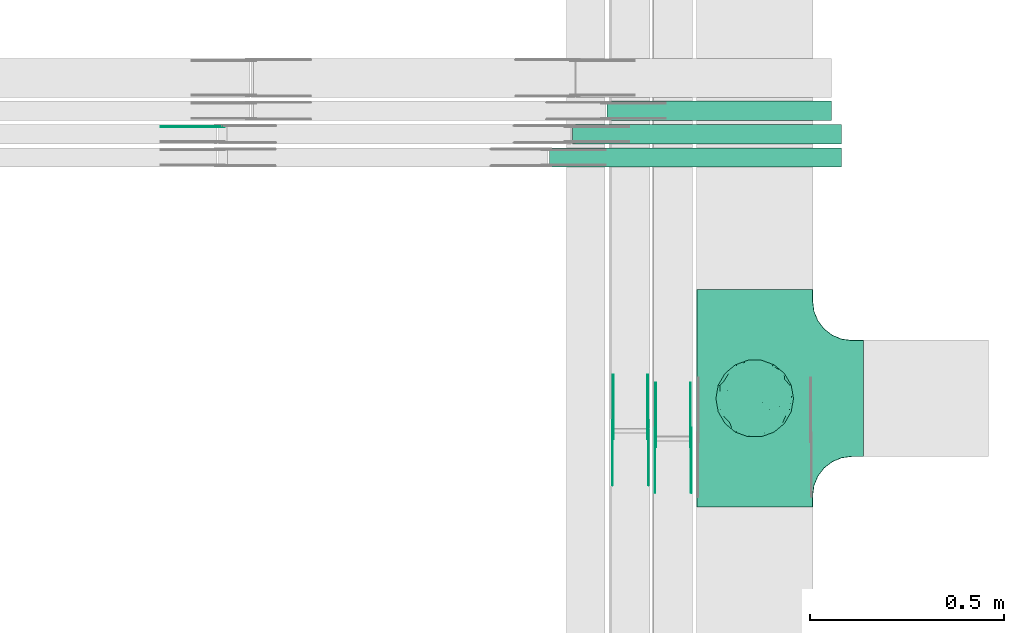
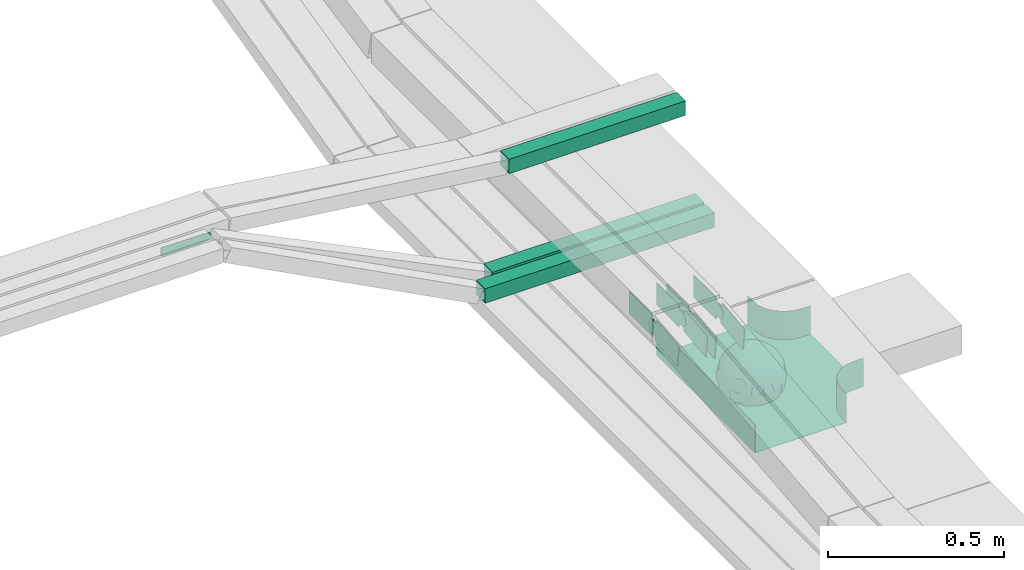
# One storey, part 6 of 32: 10 flow fittings, 3 flow segments.
"""IFC2X3 building model written with IfcOpenShell, lengths in millimetres."""

from ifc_helpers import new_model, entity, si_unit, converted_unit, derived_unit, direction, frame, frame_2d, origin, origin_2d_with_axis, place, context, subcontext, project, spatial, polyline, circle_curve, parameter, trimmed, segment, composite_curve, rectangle, outline, extrude, faceted_brep, source, transform, mapped, material, material_list, type_object, type_shapes, element, save


model = new_model("IFC2X3")

# Units and contexts
model_context = context("Model", 3, precision=0.01, world=origin(), true_north=direction((6.12303176911189e-17, 1.0)))
body_context = subcontext(model_context, "Body", "Model", "MODEL_VIEW")
ifc_project = project(units=[si_unit("LENGTHUNIT", "METRE", prefix="MILLI"), si_unit("AREAUNIT", "SQUARE_METRE"), si_unit("VOLUMEUNIT", "CUBIC_METRE"), converted_unit("PLANEANGLEUNIT", "DEGREE", entity("IfcRatioMeasure", 0.0174532925199433), si_unit("PLANEANGLEUNIT", "RADIAN"), dimensions=[0, 0, 0, 0, 0, 0, 0]), si_unit("MASSUNIT", "GRAM", prefix="KILO"), derived_unit("MASSDENSITYUNIT", [(si_unit("MASSUNIT", "GRAM", prefix="KILO"), 1), (si_unit("LENGTHUNIT", "METRE"), -3)]), derived_unit("MOMENTOFINERTIAUNIT", [(si_unit("LENGTHUNIT", "METRE"), 4)]), si_unit("TIMEUNIT", "SECOND"), si_unit("FREQUENCYUNIT", "HERTZ"), si_unit("THERMODYNAMICTEMPERATUREUNIT", "DEGREE_CELSIUS"), derived_unit("THERMALTRANSMITTANCEUNIT", [(si_unit("MASSUNIT", "GRAM", prefix="KILO"), 1), (si_unit("THERMODYNAMICTEMPERATUREUNIT", "KELVIN"), -1), (si_unit("TIMEUNIT", "SECOND"), -3)]), derived_unit("VOLUMETRICFLOWRATEUNIT", [(si_unit("LENGTHUNIT", "METRE"), 3), (si_unit("TIMEUNIT", "SECOND"), -1)]), derived_unit("MASSFLOWRATEUNIT", [(si_unit("MASSUNIT", "GRAM", prefix="KILO"), 1), (si_unit("TIMEUNIT", "SECOND"), -1)]), derived_unit("ROTATIONALFREQUENCYUNIT", [(si_unit("TIMEUNIT", "SECOND"), -1)]), si_unit("ELECTRICCURRENTUNIT", "AMPERE"), si_unit("ELECTRICVOLTAGEUNIT", "VOLT"), si_unit("POWERUNIT", "WATT"), si_unit("FORCEUNIT", "NEWTON", prefix="KILO"), si_unit("ILLUMINANCEUNIT", "LUX"), si_unit("LUMINOUSFLUXUNIT", "LUMEN"), si_unit("LUMINOUSINTENSITYUNIT", "CANDELA"), derived_unit("USERDEFINED", [(si_unit("MASSUNIT", "GRAM", prefix="KILO"), -1), (si_unit("LENGTHUNIT", "METRE"), -2), (si_unit("TIMEUNIT", "SECOND"), 3), (si_unit("LUMINOUSFLUXUNIT", "LUMEN"), 1)]), derived_unit("LINEARVELOCITYUNIT", [(si_unit("LENGTHUNIT", "METRE"), 1), (si_unit("TIMEUNIT", "SECOND"), -1)]), si_unit("PRESSUREUNIT", "PASCAL"), derived_unit("USERDEFINED", [(si_unit("LENGTHUNIT", "METRE"), -2), (si_unit("MASSUNIT", "GRAM", prefix="KILO"), 1), (si_unit("TIMEUNIT", "SECOND"), -2)]), derived_unit("LINEARFORCEUNIT", [(si_unit("MASSUNIT", "GRAM", prefix="KILO"), 1), (si_unit("LENGTHUNIT", "METRE"), 1), (si_unit("TIMEUNIT", "SECOND"), -2), (si_unit("LENGTHUNIT", "METRE"), -1)]), derived_unit("PLANARFORCEUNIT", [(si_unit("MASSUNIT", "GRAM", prefix="KILO"), 1), (si_unit("LENGTHUNIT", "METRE"), 1), (si_unit("TIMEUNIT", "SECOND"), -2), (si_unit("LENGTHUNIT", "METRE"), -2)])], contexts=[model_context])

# Site, building, storey
site_placement = place(None, origin())
site = spatial("IfcSite", under=ifc_project, at=site_placement, CompositionType="ELEMENT")
building_placement = place(site_placement, origin())
building = spatial("IfcBuilding", under=site, at=building_placement, CompositionType="ELEMENT")
storey_placement = place(building_placement, frame((0.0, 0.0, 8100.0)))
storey = spatial("IfcBuildingStorey", under=building, at=storey_placement, CompositionType="ELEMENT", Elevation=8100.0)

# Flow segments
cable_carrier_segment_type = type_object("IfcCableCarrierSegmentType", PredefinedType="CABLETRAYSEGMENT")
flow_segment_1_placement = place(storey_placement, frame((18016.07, 12091.75, 2943.75)))
element("IfcFlowSegment", 1, at=flow_segment_1_placement, inside=storey, type_object=cable_carrier_segment_type, context=body_context, shape_type="SweptSolid", body=[
    extrude(rectangle(XDim=577.162395130562, YDim=50.0000000000016, at=origin_2d_with_axis()), frame((288.58, 25.0, 0.0), z_axis=(0.0, 0.0, 1.0), x_axis=(-1.0, 0.0, 0.0)), (0.0, 0.0, 1.0), 50.0000000000016),
])
flow_segment_2_placement = place(storey_placement, frame((17927.29, 12031.75, 2620.0)))
element("IfcFlowSegment", 2, at=flow_segment_2_placement, inside=storey, type_object=cable_carrier_segment_type, context=body_context, shape_type="SweptSolid", body=[
    extrude(rectangle(XDim=692.290561126432, YDim=50.0000000000016, at=origin_2d_with_axis()), frame((346.15, 25.0, 0.0), z_axis=(0.0, 0.0, 1.0), x_axis=(-1.0, 0.0, 0.0)), (0.0, 0.0, 1.0), 50.0000000000016),
])
flow_segment_3_placement = place(storey_placement, frame((17867.72, 11971.75, 2620.0)))
element("IfcFlowSegment", 3, at=flow_segment_3_placement, inside=storey, type_object=cable_carrier_segment_type, context=body_context, shape_type="SweptSolid", body=[
    extrude(rectangle(XDim=751.864578519647, YDim=50.0000000000016, at=origin_2d_with_axis()), frame((375.93, 25.0, 0.0), z_axis=(0.0, 0.0, 1.0), x_axis=(-1.0, 0.0, 0.0)), (0.0, 0.0, 1.0), 50.0000000000016),
])

# Flow fittings
ifc_material_1 = material()
ifc_material_2 = material()
ifc_material_list = material_list([ifc_material_1, ifc_material_2])
cable_carrier_fitting_type_1 = type_object("IfcCableCarrierFittingType", PredefinedType="NOTDEFINED", material=ifc_material_1)
shared_shape_1 = source(origin(), body_context, "Body", "Brep", [
    faceted_brep([(76.48, -37.8, -52.17), (89.29, -26.17, -36.65), (85.27, -46.63, -23.54), (-17.29, -34.78, -92.15), (0.0, -44.16, -89.72), (-24.64, -51.58, -82.05), (76.33, -15.08, -62.82), (55.58, -29.55, -77.71), (-17.1, 96.98, 0.0), (-18.67, 88.89, -41.84), (-33.9, 89.53, -28.9), (-45.46, -10.48, -88.45), (-19.82, 5.04, -97.89), (-23.66, -16.13, -95.81), (92.54, 33.68, 0.0), (85.28, 45.77, -25.16), (86.6, 50.0, 0.0), (49.24, -85.29, 0.0), (62.2, -72.19, -30.32), (64.28, -76.6, 0.0), (97.17, -8.72, -21.95), (90.76, 0.0, -41.98), (96.14, 14.4, -23.44), (98.48, 17.36, 0.0), (98.48, 0.0, 0.0), (79.01, 8.48, -60.71), (76.48, 37.8, -52.17), (87.7, 23.44, -41.95), (29.16, -37.6, -87.95), (20.3, -63.77, -74.31), (-69.62, 53.19, -48.2), (-47.21, 56.75, -67.46), (-61.6, 43.47, -65.69), (29.45, 71.32, -63.61), (47.21, 56.75, -67.46), (30.04, 49.65, -81.44), (-49.67, -77.09, -39.87), (-34.2, -93.97, 0.0), (-49.24, -85.29, 0.0), (61.4, 65.14, -44.57), (74.68, 59.14, -30.41), (61.95, 44.54, -64.64), (28.77, -89.42, -34.29), (34.2, -93.97, 0.0), (25.65, -95.48, 0.0), (17.1, -96.98, 0.0), (-64.28, -76.6, 0.0), (-75.44, -63.3, 0.0), (-74.75, -61.55, -24.99), (7.5, -83.69, -54.22), (36.49, -70.37, -60.97), (-76.48, -37.8, -52.17), (-87.07, -22.49, -43.74), (-79.06, -6.54, -60.88), (63.53, 0.0, -77.22), (-63.53, 0.0, -77.22), (-81.93, 16.04, -55.05), (-98.48, -17.36, 0.0), (-95.57, -17.05, -24.0), (-92.54, -33.68, 0.0), (65.86, 23.41, -71.51), (-19.3, 70.27, -68.49), (-44.33, 79.42, -41.56), (-76.48, 37.8, -52.17), (-45.05, 37.36, -81.09), (-67.2, 22.41, -70.59), (45.89, 15.54, -87.48), (-67.14, -22.46, -70.63), (-97.69, 5.09, -20.78), (-90.76, 0.0, -41.98), (-92.54, 33.68, 0.0), (-92.15, 27.2, -27.72), (28.87, 87.52, -38.83), (7.5, 83.69, -54.22), (1.23, 95.73, -28.9), (3.52, -95.84, -28.34), (-8.55, -98.49, 0.0), (-12.28, -96.15, -24.6), (75.44, 63.3, 0.0), (64.28, 76.6, 0.0), (75.44, -63.3, 0.0), (86.6, -50.0, 0.0), (-75.44, 63.3, 0.0), (-84.89, 46.81, -24.54), (-86.6, 50.0, 0.0), (-65.62, -61.39, -43.88), (-47.21, -56.75, -67.46), (-85.24, -44.68, -27.17), (46.02, 37.17, -80.63), (-63.18, 67.68, -37.79), (-7.15, -67.62, -73.33), (31.54, -5.3, -94.75), (9.85, -20.5, -97.38), (0.0, 13.3, -99.11), (49.35, -11.18, -86.25), (92.54, -33.68, 0.0), (98.48, -17.36, 0.0), (49.24, 85.29, 0.0), (46.4, 79.11, -39.86), (34.2, 93.97, 0.0), (-53.11, 15.12, -83.37), (64.53, -54.17, -53.86), (47.21, -56.75, -67.46), (22.89, 27.57, -93.36), (74.68, -59.14, -30.41), (46.4, -79.11, -39.86), (-15.74, 23.19, -95.99), (2.81, 33.98, -94.01), (9.21, 52.39, -84.68), (9.73, 69.75, -71.0), (17.1, 96.98, 0.0), (-5.62, -90.16, -42.88), (0.0, -100.0, 0.0), (-25.13, -93.37, -25.51), (-25.95, -84.88, -46.06), (-17.1, -96.98, 0.0), (-10.24, -80.78, -58.05), (-31.24, -69.76, -64.48), (-42.19, -33.64, -84.2), (-35.78, 18.55, -91.52), (-61.62, -43.52, -65.64), (-17.34, 40.89, -89.6), (-29.1, 55.69, -77.79), (-10.66, 57.03, -81.45), (-59.77, -75.57, -26.75), (-86.6, -50.0, 0.0), (-98.48, 0.0, 0.0), (-98.48, 17.36, 0.0), (-74.77, 60.7, -26.92), (-64.28, 76.6, 0.0), (-49.24, 85.29, 0.0), (-34.2, 93.97, 0.0), (0.0, 100.0, 0.0), (-76.48, -37.8, 52.17), (-89.29, -26.17, 36.65), (-85.27, -46.63, 23.54), (17.29, -34.78, 92.15), (0.0, -44.16, 89.72), (24.64, -51.58, 82.05), (-76.33, -15.08, 62.82), (-55.58, -29.55, 77.71), (18.67, 88.89, 41.84), (33.9, 89.53, 28.9), (17.34, 40.89, 89.6), (15.74, 23.19, 95.99), (35.78, 18.55, 91.52), (-85.28, 45.77, 25.16), (-62.2, -72.19, 30.32), (-97.17, -8.72, 21.95), (-96.14, 14.4, 23.44), (-79.01, 8.48, 60.71), (-76.48, 37.8, 52.17), (-87.7, 23.44, 41.95), (-29.16, -37.6, 87.95), (-20.3, -63.77, 74.31), (69.62, 53.19, 48.2), (47.21, 56.75, 67.46), (61.6, 43.47, 65.69), (-61.4, 65.14, 44.57), (49.27, -77.35, 39.88), (-74.68, 59.14, 30.41), (-61.95, 44.54, 64.64), (-7.5, -83.69, 54.22), (-36.49, -70.37, 60.97), (-28.77, -89.42, 34.29), (74.74, -61.65, 24.74), (3.0, -95.52, 29.45), (-13.47, -92.75, 34.88), (76.48, -37.8, 52.17), (87.07, -22.49, 43.74), (79.06, -6.54, 60.88), (-63.53, 0.0, 77.22), (63.53, 0.0, 77.22), (81.93, 16.04, 55.05), (95.57, -17.05, 24.0), (-65.86, 23.41, 71.51), (19.3, 70.27, 68.49), (44.33, 79.42, 41.56), (76.48, 37.8, 52.17), (45.05, 37.36, 81.09), (67.2, 22.41, 70.59), (-45.89, 15.54, 87.48), (67.14, -22.46, 70.63), (97.69, 5.09, 20.78), (90.76, 0.0, 41.98), (92.15, 27.2, 27.72), (-28.87, 87.52, 38.83), (-7.5, 83.69, 54.22), (-1.23, 95.73, 28.9), (7.15, -67.62, 73.33), (30.04, -71.02, 63.66), (-90.76, 0.0, 41.98), (84.89, 46.81, 24.54), (65.66, -61.85, 43.17), (47.21, -56.75, 67.46), (85.24, -44.68, 27.17), (-30.04, 49.65, 81.44), (-47.21, 56.75, 67.46), (-46.02, 37.17, 80.63), (63.18, 67.68, 37.79), (-31.54, -5.3, 94.75), (-9.85, -20.5, 97.38), (0.0, 13.3, 99.11), (-49.35, -11.18, 86.25), (-46.4, 79.11, 39.86), (-29.45, 71.32, 63.61), (24.31, -93.79, 24.74), (-64.53, -54.17, 53.86), (-47.21, -56.75, 67.46), (-22.89, 27.57, 93.36), (-46.4, -79.11, 39.86), (-74.68, -59.14, 30.41), (19.82, 5.04, 97.89), (-2.81, 33.98, 94.01), (-9.21, 52.39, 84.68), (-9.73, 69.75, 71.0), (9.65, -80.54, 58.49), (23.47, -86.31, 44.72), (35.11, -89.62, 27.11), (42.19, -33.64, 84.2), (23.66, -16.13, 95.81), (45.46, -10.48, 88.45), (61.62, -43.52, 65.64), (29.1, 55.69, 77.79), (10.66, 57.03, 81.45), (59.35, -75.82, 26.99), (74.77, 60.7, 26.92), (53.11, 15.12, 83.37)], [[[0, 1, 2]], [[3, 4, 5]], [[6, 0, 7]], [[8, 9, 10]], [[11, 12, 13]], [[14, 15, 16]], [[17, 18, 19]], [[20, 21, 22]], [[22, 23, 24]], [[25, 26, 27]], [[4, 28, 29]], [[30, 31, 32]], [[33, 34, 35]], [[36, 37, 38]], [[39, 40, 41]], [[42, 43, 44, 45]], [[46, 47, 48]], [[49, 50, 42]], [[51, 52, 53]], [[54, 25, 6]], [[55, 53, 56]], [[57, 58, 59]], [[26, 25, 60]], [[61, 31, 62]], [[32, 63, 30]], [[64, 65, 32]], [[54, 66, 60]], [[53, 67, 51]], [[58, 68, 69]], [[68, 70, 71]], [[72, 73, 74]], [[75, 76, 77]], [[6, 7, 54]], [[24, 20, 22]], [[78, 40, 79]], [[15, 26, 40]], [[1, 21, 20]], [[80, 2, 81]], [[63, 56, 71]], [[82, 83, 84]], [[36, 85, 86]], [[87, 58, 52]], [[35, 34, 88]], [[62, 31, 89]], [[42, 75, 49]], [[4, 29, 90]], [[91, 92, 93]], [[7, 94, 54]], [[6, 1, 0]], [[95, 81, 2]], [[24, 96, 20]], [[1, 20, 95]], [[1, 95, 2]], [[27, 22, 21]], [[15, 14, 22]], [[25, 27, 21]], [[15, 78, 16]], [[41, 40, 26]], [[40, 78, 15]], [[39, 97, 79]], [[97, 98, 99]], [[40, 39, 79]], [[33, 73, 72]], [[21, 1, 6]], [[25, 54, 60]], [[64, 100, 65]], [[26, 15, 27]], [[6, 25, 21]], [[0, 101, 7]], [[102, 28, 7]], [[92, 91, 28]], [[94, 28, 91]], [[88, 34, 41]], [[54, 94, 66]], [[41, 26, 60]], [[103, 91, 93]], [[88, 41, 60]], [[20, 96, 95]], [[101, 18, 102]], [[104, 80, 19]], [[101, 0, 104]], [[18, 105, 102]], [[43, 42, 105]], [[17, 43, 105]], [[29, 28, 102]], [[28, 4, 92]], [[105, 50, 102]], [[90, 29, 49]], [[88, 60, 66]], [[41, 34, 39]], [[34, 98, 39]], [[97, 39, 98]], [[103, 66, 91]], [[88, 66, 103]], [[12, 106, 93]], [[33, 98, 34]], [[107, 103, 93]], [[35, 103, 108]], [[103, 35, 88]], [[33, 109, 73]], [[109, 35, 108]], [[110, 72, 74]], [[72, 110, 99]], [[98, 33, 72]], [[99, 98, 72]], [[80, 104, 2]], [[0, 2, 104]], [[101, 104, 18]], [[7, 101, 102]], [[19, 18, 104]], [[105, 18, 17]], [[77, 111, 75]], [[75, 45, 112]], [[113, 114, 111]], [[115, 77, 76]], [[36, 114, 37]], [[90, 5, 4]], [[75, 42, 45]], [[50, 49, 29]], [[49, 116, 90]], [[5, 117, 86]], [[90, 116, 117]], [[118, 13, 3]], [[118, 5, 86]], [[11, 119, 12]], [[67, 120, 51]], [[11, 13, 118]], [[65, 55, 56]], [[121, 122, 123]], [[90, 117, 5]], [[51, 120, 85]], [[117, 36, 86]], [[36, 117, 114]], [[46, 48, 124]], [[38, 124, 36]], [[85, 124, 48]], [[87, 125, 59]], [[125, 87, 47]], [[48, 51, 85]], [[68, 57, 126, 127]], [[59, 58, 87]], [[58, 69, 52]], [[53, 52, 69]], [[87, 52, 51]], [[56, 53, 69]], [[53, 55, 67]], [[71, 56, 69]], [[56, 63, 65]], [[71, 69, 68]], [[128, 129, 89]], [[11, 67, 55]], [[120, 118, 86]], [[32, 65, 63]], [[100, 55, 65]], [[118, 120, 67]], [[85, 120, 86]], [[129, 128, 82]], [[64, 32, 31]], [[62, 130, 131]], [[130, 62, 89]], [[9, 73, 61]], [[10, 62, 131]], [[109, 61, 73]], [[73, 9, 74]], [[64, 121, 119]], [[122, 61, 123]], [[64, 119, 100]], [[64, 31, 122]], [[107, 108, 103]], [[47, 87, 48]], [[51, 48, 87]], [[57, 68, 58]], [[64, 122, 121]], [[89, 129, 130]], [[67, 11, 118]], [[11, 55, 100]], [[82, 128, 83]], [[30, 128, 89]], [[83, 63, 71]], [[63, 83, 128]], [[84, 83, 71]], [[10, 61, 62]], [[74, 8, 132]], [[8, 74, 9]], [[110, 74, 132]], [[3, 92, 4]], [[92, 13, 12]], [[22, 27, 15]], [[14, 23, 22]], [[11, 100, 119]], [[128, 30, 63]], [[31, 30, 89]], [[28, 94, 7]], [[66, 94, 91]], [[42, 50, 105]], [[29, 102, 50]], [[106, 107, 93]], [[123, 107, 121]], [[35, 109, 33]], [[109, 108, 123]], [[75, 112, 76]], [[113, 77, 115]], [[114, 116, 111]], [[115, 37, 113]], [[37, 114, 113]], [[49, 75, 111]], [[117, 116, 114]], [[111, 77, 113]], [[49, 111, 116]], [[118, 3, 5]], [[92, 3, 13]], [[106, 119, 121]], [[92, 12, 93]], [[119, 106, 12]], [[107, 106, 121]], [[46, 124, 38]], [[85, 36, 124]], [[70, 68, 127]], [[70, 84, 71]], [[31, 61, 122]], [[109, 123, 61]], [[107, 123, 108]], [[8, 10, 131]], [[61, 10, 9]], [[133, 134, 135]], [[136, 137, 138]], [[139, 133, 140]], [[110, 141, 142]], [[143, 144, 145]], [[70, 146, 84]], [[38, 147, 46]], [[126, 57, 148]], [[149, 127, 126]], [[150, 151, 152]], [[137, 153, 154]], [[155, 156, 157]], [[130, 129, 158]], [[159, 43, 17]], [[158, 160, 161]], [[162, 163, 164]], [[19, 80, 165]], [[166, 167, 115]], [[168, 169, 170]], [[171, 150, 139]], [[172, 170, 173]], [[96, 174, 95]], [[151, 150, 175]], [[176, 156, 177]], [[157, 178, 155]], [[179, 180, 157]], [[171, 181, 175]], [[170, 182, 168]], [[174, 183, 184]], [[185, 23, 14, 16]], [[186, 187, 188]], [[138, 189, 190]], [[139, 140, 171]], [[126, 148, 149]], [[82, 160, 129]], [[146, 151, 160]], [[134, 191, 148]], [[47, 135, 125]], [[178, 173, 185]], [[78, 192, 16]], [[159, 193, 194]], [[195, 174, 169]], [[196, 197, 198]], [[177, 156, 199]], [[166, 112, 45]], [[154, 189, 137]], [[200, 201, 202]], [[140, 203, 171]], [[191, 149, 148]], [[59, 125, 135]], [[133, 139, 134]], [[134, 148, 59]], [[134, 59, 135]], [[152, 149, 191]], [[146, 70, 149]], [[150, 152, 191]], [[146, 82, 84]], [[161, 160, 151]], [[160, 82, 146]], [[204, 131, 130]], [[186, 205, 187]], [[160, 158, 129]], [[197, 196, 205]], [[191, 134, 139]], [[150, 171, 175]], [[45, 206, 166]], [[151, 146, 152]], [[139, 150, 191]], [[133, 207, 140]], [[208, 153, 140]], [[201, 200, 153]], [[203, 153, 200]], [[198, 197, 161]], [[171, 203, 181]], [[161, 151, 175]], [[209, 200, 202]], [[198, 161, 175]], [[148, 57, 59]], [[38, 37, 210]], [[211, 47, 46]], [[207, 133, 211]], [[147, 210, 208]], [[210, 37, 164]], [[208, 207, 147]], [[154, 153, 208]], [[153, 137, 201]], [[210, 163, 208]], [[189, 154, 162]], [[198, 175, 181]], [[161, 197, 158]], [[197, 204, 158]], [[130, 158, 204]], [[209, 181, 200]], [[198, 181, 209]], [[212, 144, 202]], [[205, 204, 197]], [[213, 209, 202]], [[196, 209, 214]], [[209, 196, 198]], [[205, 215, 187]], [[215, 196, 214]], [[8, 186, 188]], [[186, 8, 131]], [[204, 205, 186]], [[131, 204, 186]], [[47, 211, 135]], [[133, 135, 211]], [[207, 211, 147]], [[140, 207, 208]], [[46, 147, 211]], [[210, 147, 38]], [[166, 115, 76, 112]], [[115, 164, 37]], [[163, 162, 154]], [[216, 166, 217]], [[138, 137, 189]], [[162, 216, 189]], [[218, 44, 43]], [[44, 218, 206]], [[189, 216, 190]], [[219, 220, 136]], [[219, 138, 194]], [[221, 145, 212]], [[182, 222, 168]], [[221, 220, 219]], [[180, 172, 173]], [[143, 223, 224]], [[168, 222, 193]], [[194, 138, 190]], [[190, 159, 194]], [[190, 217, 218]], [[19, 165, 225]], [[17, 225, 159]], [[193, 225, 165]], [[195, 81, 95]], [[81, 195, 80]], [[165, 168, 193]], [[183, 96, 24, 23]], [[95, 174, 195]], [[174, 184, 169]], [[170, 169, 184]], [[195, 169, 168]], [[173, 170, 184]], [[170, 172, 182]], [[185, 173, 184]], [[173, 178, 180]], [[185, 184, 183]], [[226, 79, 199]], [[221, 182, 172]], [[222, 219, 194]], [[157, 180, 178]], [[227, 172, 180]], [[219, 222, 182]], [[193, 222, 194]], [[79, 226, 78]], [[179, 157, 156]], [[177, 97, 99]], [[97, 177, 199]], [[141, 187, 176]], [[142, 177, 99]], [[215, 176, 187]], [[187, 141, 188]], [[179, 143, 145]], [[223, 176, 224]], [[179, 145, 227]], [[179, 156, 223]], [[213, 214, 209]], [[96, 183, 174]], [[185, 183, 23]], [[80, 195, 165]], [[168, 165, 195]], [[199, 79, 97]], [[182, 221, 219]], [[221, 172, 227]], [[78, 226, 192]], [[155, 226, 199]], [[192, 178, 185]], [[178, 192, 226]], [[16, 192, 185]], [[142, 176, 177]], [[188, 110, 132]], [[110, 188, 141]], [[8, 188, 132]], [[136, 201, 137]], [[201, 220, 212]], [[149, 152, 146]], [[70, 127, 149]], [[167, 162, 164]], [[179, 227, 180]], [[221, 227, 145]], [[226, 155, 178]], [[156, 155, 199]], [[153, 203, 140]], [[181, 203, 200]], [[164, 163, 210]], [[154, 208, 163]], [[144, 213, 202]], [[224, 213, 143]], [[196, 215, 205]], [[215, 214, 224]], [[166, 216, 162]], [[190, 216, 217]], [[218, 217, 206]], [[43, 159, 218]], [[190, 218, 159]], [[166, 206, 217]], [[44, 206, 45]], [[219, 136, 138]], [[201, 136, 220]], [[201, 212, 202]], [[221, 212, 220]], [[145, 144, 212]], [[213, 144, 143]], [[19, 225, 17]], [[193, 159, 225]], [[179, 223, 143]], [[156, 176, 223]], [[215, 224, 176]], [[213, 224, 214]], [[110, 142, 99]], [[176, 142, 141]], [[115, 167, 164]], [[166, 162, 167]]]),
    faceted_brep([(-153.41, -224.12, 50.0), (-150.0, -250.0, 50.0), (-150.0, -280.0, 50.0), (-149.2, -280.0, 50.0), (-149.2, -250.0, 50.0), (-152.63, -223.91, 50.0), (-162.7, -199.6, 50.0), (-178.72, -178.72, 50.0), (-199.6, -162.7, 50.0), (-223.91, -152.63, 50.0), (-250.0, -149.2, 50.0), (-280.0, -149.2, 50.0), (-280.0, -150.0, 50.0), (-250.0, -150.0, 50.0), (-224.12, -153.41, 50.0), (-200.0, -163.4, 50.0), (-179.29, -179.29, 50.0), (-163.4, -200.0, 50.0), (280.0, -150.0, 50.0), (280.0, -149.2, 50.0), (250.0, -149.2, 50.0), (223.91, -152.63, 50.0), (199.6, -162.7, 50.0), (178.72, -178.72, 50.0), (162.7, -199.6, 50.0), (152.63, -223.91, 50.0), (149.2, -250.0, 50.0), (149.2, -280.0, 50.0), (150.0, -280.0, 50.0), (150.0, -250.0, 50.0), (153.41, -224.12, 50.0), (163.4, -200.0, 50.0), (179.29, -179.29, 50.0), (200.0, -163.4, 50.0), (224.12, -153.41, 50.0), (250.0, -150.0, 50.0), (280.0, 149.2, 50.0), (280.0, 150.0, 50.0), (-280.0, 150.0, 50.0), (-280.0, 149.2, 50.0), (-280.0, -150.0, -50.0), (-280.0, 150.0, -50.0), (280.0, 150.0, -50.0), (280.0, -150.0, -50.0), (250.0, -150.0, -50.0), (224.12, -153.41, -50.0), (200.0, -163.4, -50.0), (179.29, -179.29, -50.0), (163.4, -200.0, -50.0), (153.41, -224.12, -50.0), (150.0, -250.0, -50.0), (150.0, -280.0, -50.0), (-150.0, -280.0, -50.0), (-150.0, -250.0, -50.0), (-153.41, -224.12, -50.0), (-163.4, -200.0, -50.0), (-179.29, -179.29, -50.0), (-200.0, -163.4, -50.0), (-224.12, -153.41, -50.0), (-250.0, -150.0, -50.0), (-150.0, -250.0, -49.2), (149.2, -280.0, -49.2), (-149.2, -280.0, -49.2), (-149.2, -250.0, -49.2), (-250.0, -149.2, -49.2), (-280.0, -149.2, -49.2), (280.0, -149.2, -49.2), (250.0, -149.2, -49.2), (-280.0, 149.2, -49.2), (-250.0, -150.0, -49.2), (250.0, -150.0, -49.2), (280.0, 149.2, -49.2), (149.2, -250.0, -49.2), (150.0, -250.0, -49.2), (-223.91, -152.63, -49.2), (-199.6, -162.7, -49.2), (-178.72, -178.72, -49.2), (-162.7, -199.6, -49.2), (-152.63, -223.91, -49.2), (152.63, -223.91, -49.2), (162.7, -199.6, -49.2), (178.72, -178.72, -49.2), (199.6, -162.7, -49.2), (223.91, -152.63, -49.2)], [[[0, 1, 2, 3, 4, 5, 6, 7, 8, 9, 10, 11, 12, 13, 14, 15, 16, 17]], [[18, 19, 20, 21, 22, 23, 24, 25, 26, 27, 28, 29, 30, 31, 32, 33, 34, 35]], [[36, 37, 38, 39]], [[40, 41, 42, 43, 44, 45, 46, 47, 48, 49, 50, 51, 52, 53, 54, 55, 56, 57, 58, 59]], [[2, 1, 60, 53, 52]], [[3, 2, 52, 51, 28, 27, 61, 62]], [[4, 3, 62, 63]], [[11, 10, 64, 65]], [[20, 19, 66, 67]], [[39, 38, 41, 40, 12, 11, 65, 68]], [[13, 12, 40, 59, 69]], [[18, 35, 70, 44, 43]], [[19, 18, 43, 42, 37, 36, 71, 66]], [[27, 26, 72, 61]], [[29, 28, 51, 50, 73]], [[38, 37, 42, 41]], [[36, 39, 68, 71]], [[68, 65, 64, 74, 75, 76, 77, 78, 63, 62, 61, 72, 79, 80, 81, 82, 83, 67, 66, 71]], [[14, 13, 69, 59, 58]], [[15, 14, 58, 57]], [[57, 56, 16, 15]], [[17, 16, 56, 55]], [[0, 17, 55, 54]], [[1, 0, 54, 53, 60]], [[5, 78, 77, 6]], [[6, 77, 76, 7]], [[63, 78, 5, 4]], [[8, 75, 74, 9]], [[9, 74, 64, 10]], [[7, 76, 75, 8]], [[21, 83, 82, 22]], [[22, 82, 81, 23]], [[67, 83, 21, 20]], [[24, 80, 79, 25]], [[25, 79, 72, 26]], [[23, 81, 80, 24]], [[30, 29, 73, 50, 49]], [[31, 30, 49, 48]], [[32, 31, 48, 47]], [[34, 33, 46, 45]], [[34, 45, 44, 70, 35]], [[46, 33, 32, 47]]]),
])
type_shapes(cable_carrier_fitting_type_1, [shared_shape_1])
flow_fitting_1_placement = place(storey_placement, frame((18396.05, 11376.25, 2550.0), z_axis=(0.0, 0.0, 1.0), x_axis=(0.0, 1.0, 0.0)))
element("IfcFlowFitting", 4, at=flow_fitting_1_placement, inside=storey, type_object=cable_carrier_fitting_type_1, material=ifc_material_list, Name="470_DKC_S5_T", context=body_context, shape_type="MappedRepresentation", body=[
    mapped(shared_shape_1, transform((0.0, 0.0, 0.0), scale=1.0)),
])
ifc_material_3 = material(Name="G")
cable_carrier_fitting_type_2 = type_object("IfcCableCarrierFittingType", PredefinedType="NOTDEFINED", material=ifc_material_3)
shared_shape_2 = source(origin(), body_context, "Body", "SweptSolid", [
    extrude(outline(composite_curve([segment(trimmed(circle_curve(frame_2d((-44.59, 0.0), x_axis=(1.0, 0.0)), 12.5), [parameter(90.0000000000007)], [parameter(270.0)], True, "PARAMETER"), True, "CONTINUOUS"), segment(polyline([(-44.59, -12.5), (-33.09, -12.5)]), True, "CONTINUOUS"), segment(polyline([(-33.09, -12.5), (-31.23, -14.5)]), True, "CONTINUOUS"), segment(polyline([(-31.23, -14.5), (108.91, -14.5)]), True, "CONTINUOUS"), segment(polyline([(108.91, -14.5), (108.91, 14.5)]), True, "CONTINUOUS"), segment(polyline([(108.91, 14.5), (-31.23, 14.5)]), True, "CONTINUOUS"), segment(polyline([(-31.23, 14.5), (-33.09, 12.5)]), True, "CONTINUOUS"), segment(polyline([(-33.09, 12.5), (-44.59, 12.5)]), True, "CONTINUOUS")], self_intersect=False)), frame((44.59, 0.0, 0.0)), (0.0, 0.0, 1.0), 2.0),
])
type_shapes(cable_carrier_fitting_type_2, [shared_shape_2])
flow_fitting_2_placement = place(storey_placement, frame((17019.58, 12075.21, 3085.0), z_axis=(0.0, 1.0, 0.0), x_axis=(-1.0, 0.0, 0.0)))
element("IfcFlowFitting", 5, at=flow_fitting_2_placement, inside=storey, type_object=cable_carrier_fitting_type_2, material=ifc_material_3, context=body_context, shape_type="MappedRepresentation", body=[
    mapped(shared_shape_2, transform((0.0, 0.0, 0.0), scale=1.0)),
])
cable_carrier_fitting_type_3 = type_object("IfcCableCarrierFittingType", PredefinedType="NOTDEFINED", material=ifc_material_3)
shared_shape_3 = source(origin(), body_context, "Body", "SweptSolid", [
    extrude(outline(composite_curve([segment(trimmed(circle_curve(frame_2d((-41.47, 0.0), x_axis=(1.0, 0.0)), 25.0), [parameter(90.0000000000007)], [parameter(270.0)], True, "PARAMETER"), True, "CONTINUOUS"), segment(polyline([(-41.47, -25.0), (-29.97, -25.0)]), True, "CONTINUOUS"), segment(polyline([(-29.97, -25.0), (-28.1, -38.5)]), True, "CONTINUOUS"), segment(polyline([(-28.1, -38.5), (99.53, -38.5)]), True, "CONTINUOUS"), segment(polyline([(99.53, -38.5), (99.53, 38.5)]), True, "CONTINUOUS"), segment(polyline([(99.53, 38.5), (-28.1, 38.5)]), True, "CONTINUOUS"), segment(polyline([(-28.1, 38.5), (-29.97, 25.0)]), True, "CONTINUOUS"), segment(polyline([(-29.97, 25.0), (-41.47, 25.0)]), True, "CONTINUOUS")], self_intersect=False)), frame((41.47, 0.0, 0.0), z_axis=(0.0, 0.0, -1.0), x_axis=(1.0, 0.0, 0.0)), (0.0, 0.0, -1.0), 2.0),
])
type_shapes(cable_carrier_fitting_type_3, [shared_shape_3])
flow_fitting_3_placement = place(storey_placement, frame((18121.51, 11295.78, 2890.0), z_axis=(1.0, 0.0, 0.0), x_axis=(0.0, -0.994903033239732, -0.100836275468608)))
element("IfcFlowFitting", 6, at=flow_fitting_3_placement, inside=storey, type_object=cable_carrier_fitting_type_3, material=ifc_material_3, context=body_context, shape_type="MappedRepresentation", body=[
    mapped(shared_shape_3, transform((0.0, 0.0, 0.0), scale=1.0)),
])
cable_carrier_fitting_type_4 = type_object("IfcCableCarrierFittingType", PredefinedType="NOTDEFINED", material=ifc_material_3)
type_shapes(cable_carrier_fitting_type_4, [shared_shape_3])
flow_fitting_4_placement = place(storey_placement, frame((18032.59, 11295.78, 2890.0), z_axis=(-1.0, 0.0, 0.0), x_axis=(0.0, 1.0, 0.0)))
element("IfcFlowFitting", 7, at=flow_fitting_4_placement, inside=storey, type_object=cable_carrier_fitting_type_4, material=ifc_material_3, context=body_context, shape_type="MappedRepresentation", body=[
    mapped(shared_shape_3, transform((0.0, 0.0, 0.0), scale=1.0)),
])
flow_fitting_5_placement = place(storey_placement, frame((18231.51, 11275.78, 2890.0), z_axis=(1.0, 0.0, 0.0), x_axis=(0.0, -0.994821450765371, -0.101637990422292)))
element("IfcFlowFitting", 8, at=flow_fitting_5_placement, inside=storey, type_object=cable_carrier_fitting_type_3, material=ifc_material_3, context=body_context, shape_type="MappedRepresentation", body=[
    mapped(shared_shape_3, transform((0.0, 0.0, 0.0), scale=1.0)),
])
flow_fitting_6_placement = place(storey_placement, frame((18142.59, 11275.78, 2890.0), z_axis=(-1.0, 0.0, 0.0), x_axis=(0.0, 1.0, 0.0)))
element("IfcFlowFitting", 9, at=flow_fitting_6_placement, inside=storey, type_object=cable_carrier_fitting_type_4, material=ifc_material_3, context=body_context, shape_type="MappedRepresentation", body=[
    mapped(shared_shape_3, transform((0.0, 0.0, 0.0), scale=1.0)),
])
cable_carrier_fitting_type_5 = type_object("IfcCableCarrierFittingType", PredefinedType="NOTDEFINED", material=ifc_material_3)
shared_shape_4 = source(origin(), body_context, "Body", "SweptSolid", [
    extrude(outline(composite_curve([segment(trimmed(circle_curve(frame_2d((-41.47, 0.0), x_axis=(1.0, 0.0)), 25.0), [parameter(90.0000000000007)], [parameter(270.0)], True, "PARAMETER"), True, "CONTINUOUS"), segment(polyline([(-41.47, -25.0), (-29.97, -25.0)]), True, "CONTINUOUS"), segment(polyline([(-29.97, -25.0), (-28.1, -38.5)]), True, "CONTINUOUS"), segment(polyline([(-28.1, -38.5), (99.53, -38.5)]), True, "CONTINUOUS"), segment(polyline([(99.53, -38.5), (99.53, 38.5)]), True, "CONTINUOUS"), segment(polyline([(99.53, 38.5), (-28.1, 38.5)]), True, "CONTINUOUS"), segment(polyline([(-28.1, 38.5), (-29.97, 25.0)]), True, "CONTINUOUS"), segment(polyline([(-29.97, 25.0), (-41.47, 25.0)]), True, "CONTINUOUS")], self_intersect=False)), frame((41.47, 0.0, 0.0)), (0.0, 0.0, 1.0), 2.0),
])
type_shapes(cable_carrier_fitting_type_5, [shared_shape_4])
flow_fitting_7_placement = place(storey_placement, frame((18030.59, 11295.78, 2890.0), z_axis=(-1.0, 0.0, 0.0), x_axis=(0.0, -0.994903033239732, -0.100836275468608)))
element("IfcFlowFitting", 10, at=flow_fitting_7_placement, inside=storey, type_object=cable_carrier_fitting_type_5, material=ifc_material_3, context=body_context, shape_type="MappedRepresentation", body=[
    mapped(shared_shape_4, transform((0.0, 0.0, 0.0), scale=1.0)),
])
cable_carrier_fitting_type_6 = type_object("IfcCableCarrierFittingType", PredefinedType="NOTDEFINED", material=ifc_material_3)
type_shapes(cable_carrier_fitting_type_6, [shared_shape_4])
flow_fitting_8_placement = place(storey_placement, frame((18119.51, 11295.78, 2890.0), z_axis=(1.0, 0.0, 0.0), x_axis=(0.0, 1.0, 0.0)))
element("IfcFlowFitting", 11, at=flow_fitting_8_placement, inside=storey, type_object=cable_carrier_fitting_type_6, material=ifc_material_3, context=body_context, shape_type="MappedRepresentation", body=[
    mapped(shared_shape_4, transform((0.0, 0.0, 0.0), scale=1.0)),
])
flow_fitting_9_placement = place(storey_placement, frame((18140.59, 11275.78, 2890.0), z_axis=(-1.0, 0.0, 0.0), x_axis=(0.0, -0.994821450765371, -0.101637990422292)))
element("IfcFlowFitting", 12, at=flow_fitting_9_placement, inside=storey, type_object=cable_carrier_fitting_type_5, material=ifc_material_3, context=body_context, shape_type="MappedRepresentation", body=[
    mapped(shared_shape_4, transform((0.0, 0.0, 0.0), scale=1.0)),
])
flow_fitting_10_placement = place(storey_placement, frame((18229.51, 11275.78, 2890.0), z_axis=(1.0, 0.0, 0.0), x_axis=(0.0, 1.0, 0.0)))
element("IfcFlowFitting", 13, at=flow_fitting_10_placement, inside=storey, type_object=cable_carrier_fitting_type_6, material=ifc_material_3, context=body_context, shape_type="MappedRepresentation", body=[
    mapped(shared_shape_4, transform((0.0, 0.0, 0.0), scale=1.0)),
])

save(model, "model.ifc")
